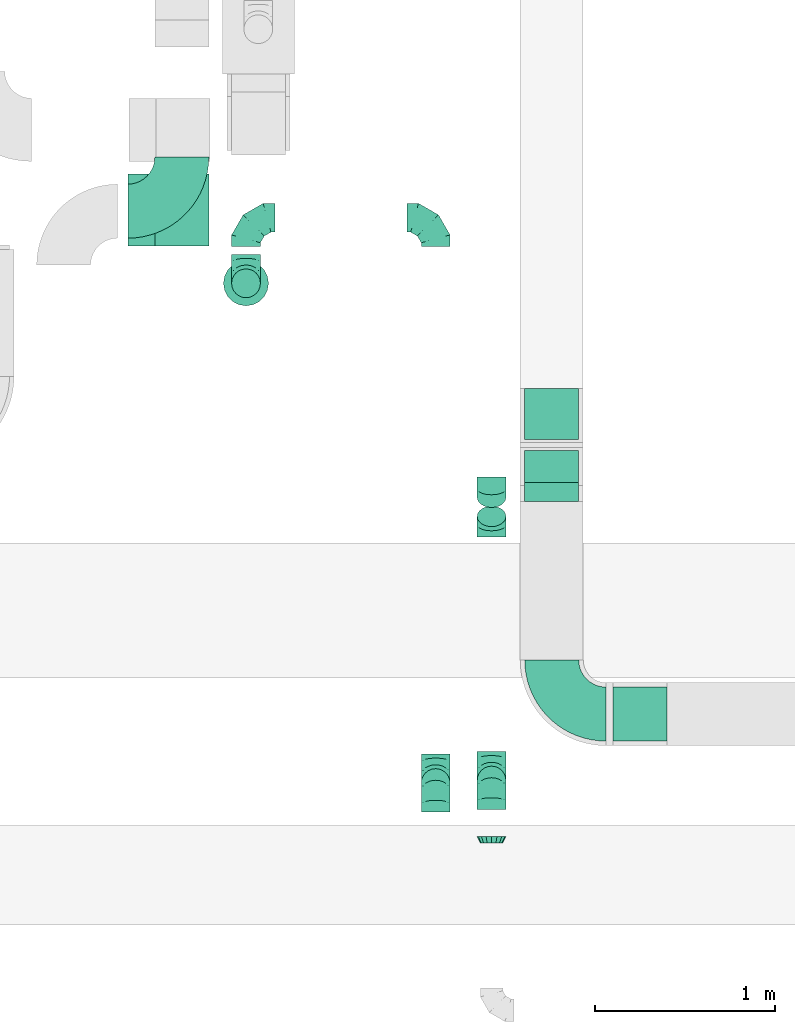
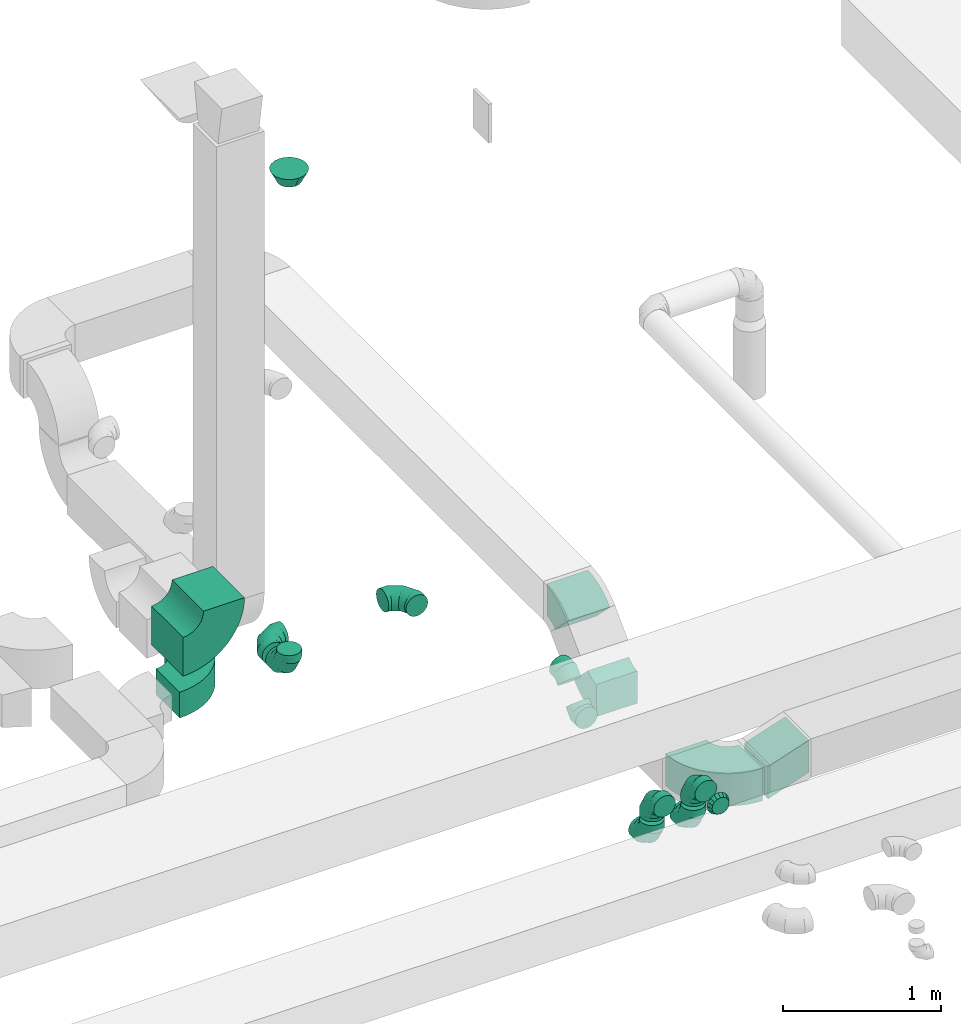
# One storey, part 44 of 97: 17 flow fittings.
"""IFC2X3 building model written with IfcOpenShell, lengths in millimetres."""

from ifc_helpers import new_model, entity, si_unit, converted_unit, derived_unit, direction, frame, frame_2d, origin, place, context, subcontext, project, spatial, polyline, circle_curve, parameter, trimmed, segment, composite_curve, outline, extrude, faceted_brep, source, transform, mapped, material, type_object, type_shapes, element, save


model = new_model("IFC2X3")

# Units and contexts
model_context = context("Model", 3, precision=0.01, world=origin(), true_north=direction((6.12303176911189e-17, 1.0)))
body_context = subcontext(model_context, "Body", "Model", "MODEL_VIEW")
ifc_project = project(units=[si_unit("LENGTHUNIT", "METRE", prefix="MILLI"), si_unit("AREAUNIT", "SQUARE_METRE"), si_unit("VOLUMEUNIT", "CUBIC_METRE"), converted_unit("PLANEANGLEUNIT", "DEGREE", entity("IfcRatioMeasure", 0.0174532925199433), si_unit("PLANEANGLEUNIT", "RADIAN"), dimensions=[0, 0, 0, 0, 0, 0, 0]), si_unit("MASSUNIT", "GRAM", prefix="KILO"), derived_unit("MASSDENSITYUNIT", [(si_unit("MASSUNIT", "GRAM", prefix="KILO"), 1), (si_unit("LENGTHUNIT", "METRE"), -3)]), derived_unit("MOMENTOFINERTIAUNIT", [(si_unit("LENGTHUNIT", "METRE"), 4)]), si_unit("TIMEUNIT", "SECOND"), si_unit("FREQUENCYUNIT", "HERTZ"), si_unit("THERMODYNAMICTEMPERATUREUNIT", "DEGREE_CELSIUS"), derived_unit("THERMALTRANSMITTANCEUNIT", [(si_unit("MASSUNIT", "GRAM", prefix="KILO"), 1), (si_unit("THERMODYNAMICTEMPERATUREUNIT", "KELVIN"), -1), (si_unit("TIMEUNIT", "SECOND"), -3)]), derived_unit("VOLUMETRICFLOWRATEUNIT", [(si_unit("LENGTHUNIT", "METRE"), 3), (si_unit("TIMEUNIT", "SECOND"), -1)]), derived_unit("MASSFLOWRATEUNIT", [(si_unit("MASSUNIT", "GRAM", prefix="KILO"), 1), (si_unit("TIMEUNIT", "SECOND"), -1)]), derived_unit("ROTATIONALFREQUENCYUNIT", [(si_unit("TIMEUNIT", "SECOND"), -1)]), si_unit("ELECTRICCURRENTUNIT", "AMPERE"), si_unit("ELECTRICVOLTAGEUNIT", "VOLT"), si_unit("POWERUNIT", "WATT"), si_unit("FORCEUNIT", "NEWTON", prefix="KILO"), si_unit("ILLUMINANCEUNIT", "LUX"), si_unit("LUMINOUSFLUXUNIT", "LUMEN"), si_unit("LUMINOUSINTENSITYUNIT", "CANDELA"), derived_unit("USERDEFINED", [(si_unit("MASSUNIT", "GRAM", prefix="KILO"), -1), (si_unit("LENGTHUNIT", "METRE"), -2), (si_unit("TIMEUNIT", "SECOND"), 3), (si_unit("LUMINOUSFLUXUNIT", "LUMEN"), 1)]), derived_unit("LINEARVELOCITYUNIT", [(si_unit("LENGTHUNIT", "METRE"), 1), (si_unit("TIMEUNIT", "SECOND"), -1)]), si_unit("PRESSUREUNIT", "PASCAL"), derived_unit("USERDEFINED", [(si_unit("LENGTHUNIT", "METRE"), -2), (si_unit("MASSUNIT", "GRAM", prefix="KILO"), 1), (si_unit("TIMEUNIT", "SECOND"), -2)]), derived_unit("LINEARFORCEUNIT", [(si_unit("MASSUNIT", "GRAM", prefix="KILO"), 1), (si_unit("LENGTHUNIT", "METRE"), 1), (si_unit("TIMEUNIT", "SECOND"), -2), (si_unit("LENGTHUNIT", "METRE"), -1)]), derived_unit("PLANARFORCEUNIT", [(si_unit("MASSUNIT", "GRAM", prefix="KILO"), 1), (si_unit("LENGTHUNIT", "METRE"), 1), (si_unit("TIMEUNIT", "SECOND"), -2), (si_unit("LENGTHUNIT", "METRE"), -2)])], contexts=[model_context])

# Site, building, storey
site_placement = place(None, origin())
site = spatial("IfcSite", under=ifc_project, at=site_placement, CompositionType="ELEMENT")
building_placement = place(site_placement, origin())
building = spatial("IfcBuilding", under=site, at=building_placement, CompositionType="ELEMENT")
storey_placement = place(building_placement, frame((0.0, 0.0, -4900.0)))
storey = spatial("IfcBuildingStorey", under=building, at=storey_placement, CompositionType="ELEMENT", Elevation=-4900.0)

# Flow fittings
ifc_material = material()
duct_fitting_type_1 = type_object("IfcDuctFittingType", PredefinedType="NOTDEFINED", material=ifc_material)
shared_shape_1 = source(origin(), body_context, "Body", "SweptSolid", [
    extrude(outline(polyline([(-197.64, -118.59), (118.59, -118.59), (197.64, 118.59), (-118.59, 118.59), (-197.64, -118.59)])), frame((150.0, -150.0, -50.0), z_axis=(0.0, 1.0, 0.0), x_axis=(0.948683298050436, 0.0, -0.316227766017072)), (0.0, 0.0, 1.0), 300.0),
])
type_shapes(duct_fitting_type_1, [shared_shape_1])
flow_fitting_1_placement = place(storey_placement, frame((33827.72, 9245.01, 4000.0), z_axis=(0.0, 0.0, 1.0), x_axis=(-1.0, 0.0, 0.0)))
element("IfcFlowFitting", 1, at=flow_fitting_1_placement, inside=storey, type_object=duct_fitting_type_1, material=ifc_material, context=body_context, shape_type="MappedRepresentation", body=[
    mapped(shared_shape_1, transform((0.0, 0.0, 0.0), scale=1.0)),
])
duct_fitting_type_2 = type_object("IfcDuctFittingType", PredefinedType="NOTDEFINED", material=ifc_material)
shared_shape_2 = source(origin(), body_context, "Body", "Brep", [
    faceted_brep([(-160.0, 0.0, -80.0), (-160.0, -20.71, -77.27), (-160.0, -40.0, -69.28), (-160.0, -56.57, -56.57), (-160.0, -69.28, -40.0), (-160.0, -77.27, -20.71), (-160.0, -80.0, 0.0), (-160.0, -77.27, 20.71), (-160.0, -69.28, 40.0), (-160.0, -56.57, 56.57), (-160.0, -40.0, 69.28), (-160.0, -20.71, 77.27), (-160.0, 0.0, 80.0), (-160.0, 20.71, 77.27), (-160.0, 40.0, 69.28), (-160.0, 56.57, 56.57), (-160.0, 69.28, 40.0), (-160.0, 77.27, 20.71), (-160.0, 80.0, 0.0), (-160.0, 77.27, -20.71), (-160.0, 69.28, -40.0), (-160.0, 56.57, -56.57), (-160.0, 40.0, -69.28), (-160.0, 20.71, -77.27), (-122.68, 20.71, 77.27), (-127.85, 40.0, 69.28), (-117.13, 0.0, 80.0), (-132.29, 56.57, 56.57), (-137.83, 77.27, 20.71), (-138.56, 80.0, 0.0), (-135.69, 69.28, 40.0), (-135.69, 69.28, -40.0), (-132.29, 56.57, -56.57), (-137.83, 77.27, -20.71), (-122.68, 20.71, -77.27), (-117.13, 0.0, -80.0), (-127.85, 40.0, -69.28), (-111.58, -20.71, -77.27), (-106.41, -40.0, -69.28), (-101.97, -56.57, -56.57), (-98.56, -69.28, -40.0), (-96.42, -77.27, -20.71), (-95.69, -80.0, 0.0), (-96.42, -77.27, 20.71), (-98.56, -69.28, 40.0), (-101.97, -56.57, 56.57), (-106.41, -40.0, 69.28), (-111.58, -20.71, 77.27), (-58.03, 58.03, 77.27), (-72.15, 72.15, 69.28), (-42.87, 42.87, 80.0), (-84.28, 84.28, 56.57), (-93.59, 93.59, 40.0), (-99.44, 99.44, 20.71), (-101.44, 101.44, 0.0), (-99.44, 99.44, -20.71), (-93.59, 93.59, -40.0), (-84.28, 84.28, -56.57), (-58.03, 58.03, -77.27), (-42.87, 42.87, -80.0), (-72.15, 72.15, -69.28), (-27.71, 27.71, -77.27), (-13.59, 13.59, -69.28), (-1.46, 1.46, -56.57), (7.85, -7.85, -40.0), (13.7, -13.7, -20.71), (15.69, -15.69, 0.0), (13.7, -13.7, 20.71), (7.85, -7.85, 40.0), (-1.46, 1.46, 56.57), (-13.59, 13.59, 69.28), (-27.71, 27.71, 77.27), (-20.71, 122.68, 77.27), (-40.0, 127.85, 69.28), (0.0, 117.13, 80.0), (-56.57, 132.29, 56.57), (-69.28, 135.69, 40.0), (-77.27, 137.83, 20.71), (-80.0, 138.56, 0.0), (-77.27, 137.83, -20.71), (-69.28, 135.69, -40.0), (-56.57, 132.29, -56.57), (-20.71, 122.68, -77.27), (0.0, 117.13, -80.0), (-40.0, 127.85, -69.28), (20.71, 111.58, -77.27), (40.0, 106.41, -69.28), (56.57, 101.97, -56.57), (69.28, 98.56, -40.0), (77.27, 96.42, -20.71), (80.0, 95.69, 0.0), (77.27, 96.42, 20.71), (69.28, 98.56, 40.0), (56.57, 101.97, 56.57), (40.0, 106.41, 69.28), (20.71, 111.58, 77.27), (-20.71, 160.0, -77.27), (-40.0, 160.0, -69.28), (-56.57, 160.0, -56.57), (-69.28, 160.0, -40.0), (-77.27, 160.0, -20.71), (-80.0, 160.0, 0.0), (-77.27, 160.0, 20.71), (-69.28, 160.0, 40.0), (-56.57, 160.0, 56.57), (-40.0, 160.0, 69.28), (-20.71, 160.0, 77.27), (0.0, 160.0, 80.0), (20.71, 160.0, 77.27), (40.0, 160.0, 69.28), (56.57, 160.0, 56.57), (69.28, 160.0, 40.0), (77.27, 160.0, 20.71), (80.0, 160.0, 0.0), (77.27, 160.0, -20.71), (69.28, 160.0, -40.0), (56.57, 160.0, -56.57), (40.0, 160.0, -69.28), (20.71, 160.0, -77.27), (0.0, 160.0, -80.0)], [[[0, 1, 2, 3, 4, 5, 6, 7, 8, 9, 10, 11, 12, 13, 14, 15, 16, 17, 18, 19, 20, 21, 22, 23]], [[24, 25, 14, 13]], [[26, 24, 13, 12]], [[14, 25, 27, 15]], [[28, 29, 18, 17]], [[30, 28, 17, 16]], [[15, 27, 30, 16]], [[20, 31, 32, 21]], [[33, 31, 20, 19]], [[18, 29, 33, 19]], [[34, 35, 0, 23]], [[36, 34, 23, 22]], [[32, 36, 22, 21]], [[1, 0, 35, 37]], [[2, 1, 37, 38]], [[3, 2, 38, 39]], [[5, 4, 40, 41]], [[6, 5, 41, 42]], [[39, 40, 4, 3]], [[6, 42, 43, 7]], [[7, 43, 44, 8]], [[8, 44, 45, 9]], [[9, 45, 46, 10]], [[10, 46, 47, 11]], [[26, 12, 11, 47]], [[48, 49, 25, 24]], [[50, 48, 24, 26]], [[27, 25, 49, 51]], [[52, 53, 28, 30]], [[51, 52, 30, 27]], [[29, 28, 53, 54]], [[55, 56, 31, 33]], [[54, 55, 33, 29]], [[32, 31, 56, 57]], [[58, 59, 35, 34]], [[60, 58, 34, 36]], [[57, 60, 36, 32]], [[37, 35, 59, 61]], [[38, 37, 61, 62]], [[39, 38, 62, 63]], [[41, 40, 64, 65]], [[42, 41, 65, 66]], [[63, 64, 40, 39]], [[43, 42, 66, 67]], [[44, 43, 67, 68]], [[68, 69, 45, 44]], [[46, 45, 69, 70]], [[47, 46, 70, 71]], [[26, 47, 71, 50]], [[72, 73, 49, 48]], [[74, 72, 48, 50]], [[51, 49, 73, 75]], [[76, 77, 53, 52]], [[75, 76, 52, 51]], [[54, 53, 77, 78]], [[79, 80, 56, 55]], [[78, 79, 55, 54]], [[57, 56, 80, 81]], [[82, 83, 59, 58]], [[84, 82, 58, 60]], [[81, 84, 60, 57]], [[61, 59, 83, 85]], [[62, 61, 85, 86]], [[63, 62, 86, 87]], [[65, 64, 88, 89]], [[66, 65, 89, 90]], [[87, 88, 64, 63]], [[67, 66, 90, 91]], [[68, 67, 91, 92]], [[92, 93, 69, 68]], [[70, 69, 93, 94]], [[71, 70, 94, 95]], [[50, 71, 95, 74]], [[96, 97, 98, 99, 100, 101, 102, 103, 104, 105, 106, 107, 108, 109, 110, 111, 112, 113, 114, 115, 116, 117, 118, 119]], [[72, 74, 107, 106]], [[73, 72, 106, 105]], [[75, 73, 105, 104]], [[77, 76, 103, 102]], [[78, 77, 102, 101]], [[75, 104, 103, 76]], [[78, 101, 100, 79]], [[79, 100, 99, 80]], [[80, 99, 98, 81]], [[84, 97, 96, 82]], [[82, 96, 119, 83]], [[84, 81, 98, 97]], [[118, 117, 86, 85]], [[119, 118, 85, 83]], [[116, 87, 86, 117]], [[88, 115, 114, 89]], [[89, 114, 113, 90]], [[115, 88, 87, 116]], [[112, 111, 92, 91]], [[113, 112, 91, 90]], [[111, 110, 93, 92]], [[95, 94, 109, 108]], [[74, 95, 108, 107]], [[110, 109, 94, 93]]]),
])
type_shapes(duct_fitting_type_2, [shared_shape_2])
for number, where, z_axis, x_axis in (
    (2, (31490.77, 12001.42, 3950.0), (0.0, 0.0, 1.0), (-1.0, 0.0, 0.0)),
    (3, (31490.77, 11637.41, 3950.0), (-1.0, 0.0, 0.0), (0.0, -1.0, 0.0)),
    (4, (32854.47, 8875.84, 3950.0), (-1.0, 0.0, 0.0), (0.0, -1.0, 0.0)),
    (5, (32854.47, 8875.84, 4300.0), (1.0, 0.0, 0.0), (0.0, 0.0, 1.0)),
    (6, (32544.11, 8861.92, 4300.0), (-1.0, 0.0, 0.0), (0.0, 1.0, 0.0)),
    (7, (32544.11, 8861.92, 3950.0), (1.0, 0.0, 0.0), (0.0, 0.0, -1.0)),
    (8, (32544.11, 12001.42, 3950.0), (0.0, 0.0, 1.0), (0.0, 1.0, 0.0)),
):
    element("IfcFlowFitting", number, at=place(storey_placement, frame(where, z_axis=z_axis, x_axis=x_axis)), inside=storey, type_object=duct_fitting_type_2, material=ifc_material, context=body_context, shape_type="MappedRepresentation", body=[
        mapped(shared_shape_2, transform((0.0, 0.0, 0.0), scale=1.0)),
    ])
duct_fitting_type_3 = type_object("IfcDuctFittingType", PredefinedType="NOTDEFINED", material=ifc_material)
shared_shape_3 = source(origin(), body_context, "Body", "Brep", [
    faceted_brep([(35.0, -57.74, 23.92), (35.0, -60.12, 11.96), (35.0, -62.5, 0.0), (35.0, -60.12, -11.96), (35.0, -57.74, -23.92), (35.0, -50.97, -34.06), (35.0, -44.19, -44.19), (35.0, -34.06, -50.97), (35.0, -23.92, -57.74), (35.0, -11.96, -60.12), (35.0, 0.0, -62.5), (35.0, 11.96, -60.12), (35.0, 23.92, -57.74), (35.0, 34.06, -50.97), (35.0, 44.19, -44.19), (35.0, 50.97, -34.06), (35.0, 57.74, -23.92), (35.0, 60.12, -11.96), (35.0, 62.5, 0.0), (35.0, 60.12, 11.96), (35.0, 57.74, 23.92), (35.0, 50.97, 34.06), (35.0, 44.19, 44.19), (35.0, 34.06, 50.97), (35.0, 23.92, 57.74), (35.0, 11.96, 60.12), (35.0, 0.0, 62.5), (35.0, -11.96, 60.12), (35.0, -23.92, 57.74), (35.0, -34.06, 50.97), (35.0, -44.19, 44.19), (35.0, -50.97, 34.06), (0.0, -80.0, 0.0), (0.0, -77.45, 12.81), (0.0, -73.91, 30.61), (0.0, -65.24, 43.59), (0.0, -56.57, 56.57), (0.0, -43.59, 65.24), (0.0, -30.61, 73.91), (0.0, -12.81, 77.45), (0.0, 0.0, 80.0), (0.0, 12.81, 77.45), (0.0, 30.61, 73.91), (0.0, 43.59, 65.24), (0.0, 56.57, 56.57), (0.0, 65.24, 43.59), (0.0, 73.91, 30.61), (0.0, 77.45, 12.81), (0.0, 80.0, 0.0), (0.0, 77.45, -12.81), (0.0, 73.91, -30.61), (0.0, 65.24, -43.59), (0.0, 56.57, -56.57), (0.0, 43.59, -65.24), (0.0, 30.61, -73.91), (0.0, 12.81, -77.45), (0.0, 0.0, -80.0), (0.0, -12.81, -77.45), (0.0, -30.61, -73.91), (0.0, -43.59, -65.24), (0.0, -56.57, -56.57), (0.0, -65.24, -43.59), (0.0, -73.91, -30.61), (0.0, -77.45, -12.81)], [[[0, 1, 2, 3, 4, 5, 6, 7, 8, 9, 10, 11, 12, 13, 14, 15, 16, 17, 18, 19, 20, 21, 22, 23, 24, 25, 26, 27, 28, 29, 30, 31]], [[32, 33, 34, 35, 36, 37, 38, 39, 40, 41, 42, 43, 44, 45, 46, 47, 48, 49, 50, 51, 52, 53, 54, 55, 56, 57, 58, 59, 60, 61, 62, 63]], [[24, 23, 22, 44, 43, 42]], [[20, 46, 45, 44, 22, 21]], [[42, 41, 40, 26, 25, 24]], [[47, 46, 20, 19, 18, 48]], [[0, 31, 30, 36, 35, 34]], [[28, 38, 37, 36, 30, 29]], [[34, 33, 32, 2, 1, 0]], [[39, 38, 28, 27, 26, 40]], [[8, 7, 6, 60, 59, 58]], [[4, 62, 61, 60, 6, 5]], [[58, 57, 56, 10, 9, 8]], [[63, 62, 4, 3, 2, 32]], [[16, 15, 14, 52, 51, 50]], [[12, 54, 53, 52, 14, 13]], [[50, 49, 48, 18, 17, 16]], [[55, 54, 12, 11, 10, 56]]]),
])
type_shapes(duct_fitting_type_3, [shared_shape_3])
flow_fitting_2_placement = place(storey_placement, frame((32854.47, 8564.77, 4300.0), z_axis=(0.0, 0.0, 1.0), x_axis=(0.0, -1.0, 0.0)))
element("IfcFlowFitting", 9, at=flow_fitting_2_placement, inside=storey, type_object=duct_fitting_type_3, material=ifc_material, context=body_context, shape_type="MappedRepresentation", body=[
    mapped(shared_shape_3, transform((0.0, 0.0, 0.0), scale=1.0)),
])
duct_fitting_type_4 = type_object("IfcDuctFittingType", PredefinedType="NOTDEFINED", material=ifc_material)
shared_shape_4 = source(origin(), body_context, "Body", "Brep", [
    faceted_brep([(-66.27, 0.0, -80.0), (-66.27, -20.71, -77.27), (-66.27, -40.0, -69.28), (-66.27, -56.57, -56.57), (-66.27, -69.28, -40.0), (-66.27, -77.27, -20.71), (-66.27, -80.0, 0.0), (-66.27, -77.27, 20.71), (-66.27, -69.28, 40.0), (-66.27, -56.57, 56.57), (-66.27, -40.0, 69.28), (-66.27, -20.71, 77.27), (-66.27, 0.0, 80.0), (-66.27, 20.71, 77.27), (-66.27, 40.0, 69.28), (-66.27, 56.57, 56.57), (-66.27, 69.28, 40.0), (-66.27, 77.27, 20.71), (-66.27, 80.0, 0.0), (-66.27, 77.27, -20.71), (-66.27, 69.28, -40.0), (-66.27, 56.57, -56.57), (-66.27, 40.0, -69.28), (-66.27, 20.71, -77.27), (-8.58, 20.71, 77.27), (-16.57, 40.0, 69.28), (0.0, 0.0, 80.0), (-23.43, 56.57, 56.57), (-28.7, 69.28, 40.0), (-32.01, 77.27, 20.71), (-33.14, 80.0, 0.0), (-32.01, 77.27, -20.71), (-28.7, 69.28, -40.0), (-23.43, 56.57, -56.57), (-8.58, 20.71, -77.27), (0.0, 0.0, -80.0), (-16.57, 40.0, -69.28), (8.58, -20.71, -77.27), (16.57, -40.0, -69.28), (23.43, -56.57, -56.57), (28.7, -69.28, -40.0), (32.01, -77.27, -20.71), (33.14, -80.0, 0.0), (32.01, -77.27, 20.71), (28.7, -69.28, 40.0), (23.43, -56.57, 56.57), (16.57, -40.0, 69.28), (8.58, -20.71, 77.27), (46.86, 46.86, 80.0), (32.22, 61.5, 77.27), (18.58, 75.15, 69.28), (6.86, 86.86, 56.57), (-2.13, 95.85, 40.0), (-7.78, 101.5, 20.71), (-9.71, 103.43, 0.0), (-7.78, 101.5, -20.71), (-2.13, 95.85, -40.0), (6.86, 86.86, -56.57), (18.58, 75.15, -69.28), (32.22, 61.5, -77.27), (46.86, 46.86, -80.0), (61.5, 32.22, -77.27), (75.15, 18.58, -69.28), (86.86, 6.86, -56.57), (95.85, -2.13, -40.0), (101.5, -7.78, -20.71), (103.43, -9.71, 0.0), (101.5, -7.78, 20.71), (95.85, -2.13, 40.0), (86.86, 6.86, 56.57), (75.15, 18.58, 69.28), (61.5, 32.22, 77.27)], [[[0, 1, 2, 3, 4, 5, 6, 7, 8, 9, 10, 11, 12, 13, 14, 15, 16, 17, 18, 19, 20, 21, 22, 23]], [[24, 25, 14, 13]], [[26, 24, 13, 12]], [[14, 25, 27, 15]], [[28, 29, 17, 16]], [[28, 16, 15, 27]], [[30, 18, 17, 29]], [[31, 32, 20, 19]], [[30, 31, 19, 18]], [[32, 33, 21, 20]], [[34, 35, 0, 23]], [[36, 34, 23, 22]], [[33, 36, 22, 21]], [[1, 0, 35, 37]], [[2, 1, 37, 38]], [[38, 39, 3, 2]], [[5, 4, 40, 41]], [[6, 5, 41, 42]], [[39, 40, 4, 3]], [[6, 42, 43, 7]], [[7, 43, 44, 8]], [[8, 44, 45, 9]], [[9, 45, 46, 10]], [[10, 46, 47, 11]], [[26, 12, 11, 47]], [[24, 26, 48, 49]], [[25, 24, 49, 50]], [[27, 25, 50, 51]], [[29, 28, 52, 53]], [[30, 29, 53, 54]], [[51, 52, 28, 27]], [[30, 54, 55, 31]], [[31, 55, 56, 32]], [[57, 33, 32, 56]], [[36, 58, 59, 34]], [[34, 59, 60, 35]], [[58, 36, 33, 57]], [[35, 60, 61, 37]], [[37, 61, 62, 38]], [[63, 39, 38, 62]], [[40, 64, 65, 41]], [[41, 65, 66, 42]], [[64, 40, 39, 63]], [[43, 42, 66, 67]], [[44, 43, 67, 68]], [[68, 69, 45, 44]], [[47, 46, 70, 71]], [[26, 47, 71, 48]], [[69, 70, 46, 45]], [[59, 58, 57, 56, 55, 54, 53, 52, 51, 50, 49, 48, 71, 70, 69, 68, 67, 66, 65, 64, 63, 62, 61, 60]]]),
])
type_shapes(duct_fitting_type_4, [shared_shape_4])
for number, where, z_axis, x_axis in (
    (10, (32854.47, 10495.84, 4150.0), (1.0, 0.0, 0.0), (0.0, -1.0, 0.0)),
    (11, (32854.47, 10295.84, 3950.0), (-1.0, 0.0, 0.0), (0.0, -0.707106781186524, -0.707106781186571)),
):
    element("IfcFlowFitting", number, at=place(storey_placement, frame(where, z_axis=z_axis, x_axis=x_axis)), inside=storey, type_object=duct_fitting_type_4, material=ifc_material, context=body_context, shape_type="MappedRepresentation", body=[
        mapped(shared_shape_4, transform((0.0, 0.0, 0.0), scale=1.0)),
    ])
duct_fitting_type_5 = type_object("IfcDuctFittingType", PredefinedType="NOTDEFINED", material=ifc_material)
shared_shape_5 = source(origin(), body_context, "Body", "Brep", [
    faceted_brep([(90.0, -73.47, -101.13), (90.0, -38.63, -118.88), (90.0, 0.0, -125.0), (90.0, 38.63, -118.88), (90.0, 73.47, -101.13), (90.0, 101.13, -73.47), (90.0, 118.88, -38.63), (90.0, 125.0, 0.0), (90.0, 118.88, 38.63), (90.0, 101.13, 73.47), (90.0, 73.47, 101.13), (90.0, 38.63, 118.88), (90.0, 0.0, 125.0), (90.0, -38.63, 118.88), (90.0, -73.47, 101.13), (90.0, -101.13, 73.47), (90.0, -118.88, 38.63), (90.0, -125.0, 0.0), (90.0, -118.88, -38.63), (90.0, -101.13, -73.47), (0.0, -30.61, -73.91), (0.0, -43.59, -65.24), (0.0, -56.57, -56.57), (0.0, -65.24, -43.59), (0.0, -73.91, -30.61), (0.0, -76.96, -15.31), (0.0, -80.0, 0.0), (0.0, -76.96, 15.31), (0.0, -73.91, 30.61), (0.0, -65.24, 43.59), (0.0, -56.57, 56.57), (0.0, -43.59, 65.24), (0.0, -30.61, 73.91), (0.0, -15.31, 76.96), (0.0, 0.0, 80.0), (0.0, 15.31, 76.96), (0.0, 30.61, 73.91), (0.0, 43.59, 65.24), (0.0, 56.57, 56.57), (0.0, 65.24, 43.59), (0.0, 73.91, 30.61), (0.0, 76.96, 15.31), (0.0, 80.0, 0.0), (0.0, 76.96, -15.31), (0.0, 73.91, -30.61), (0.0, 65.24, -43.59), (0.0, 56.57, -56.57), (0.0, 43.59, -65.24), (0.0, 30.61, -73.91), (0.0, 15.31, -76.96), (0.0, 0.0, -80.0), (0.0, -15.31, -76.96)], [[[0, 1, 2, 3, 4, 5, 6, 7, 8, 9, 10, 11, 12, 13, 14, 15, 16, 17, 18, 19]], [[20, 21, 22, 23, 24, 25, 26, 27, 28, 29, 30, 31, 32, 33, 34, 35, 36, 37, 38, 39, 40, 41, 42, 43, 44, 45, 46, 47, 48, 49, 50, 51]], [[7, 41, 8]], [[41, 40, 8]], [[40, 9, 8]], [[11, 36, 35]], [[41, 7, 42]], [[9, 40, 39, 38]], [[10, 38, 37, 36]], [[12, 35, 34]], [[11, 10, 36]], [[12, 11, 35]], [[38, 10, 9]], [[12, 33, 13]], [[33, 32, 13]], [[32, 14, 13]], [[16, 28, 27]], [[33, 12, 34]], [[14, 32, 31, 30]], [[15, 30, 29, 28]], [[17, 27, 26]], [[16, 15, 28]], [[17, 16, 27]], [[30, 15, 14]], [[17, 25, 18]], [[25, 24, 18]], [[24, 19, 18]], [[1, 20, 51]], [[25, 17, 26]], [[19, 24, 23, 22]], [[0, 22, 21, 20]], [[2, 51, 50]], [[1, 0, 20]], [[2, 1, 51]], [[22, 0, 19]], [[2, 49, 3]], [[49, 48, 3]], [[48, 4, 3]], [[6, 44, 43]], [[49, 2, 50]], [[4, 48, 47, 46]], [[5, 46, 45, 44]], [[7, 43, 42]], [[6, 5, 44]], [[7, 6, 43]], [[46, 5, 4]]]),
])
type_shapes(duct_fitting_type_5, [shared_shape_5])
flow_fitting_3_placement = place(storey_placement, frame((31490.77, 11637.41, 7735.0), z_axis=(0.0, 1.0, 0.0), x_axis=(0.0, 0.0, 1.0)))
element("IfcFlowFitting", 12, at=flow_fitting_3_placement, inside=storey, type_object=duct_fitting_type_5, material=ifc_material, context=body_context, shape_type="MappedRepresentation", body=[
    mapped(shared_shape_5, transform((0.0, 0.0, 0.0), scale=1.0)),
])
duct_fitting_type_6 = type_object("IfcDuctFittingType", PredefinedType="NOTDEFINED", material=ifc_material)
shared_shape_6 = source(origin(), body_context, "Body", "SweptSolid", [
    extrude(outline(composite_curve([segment(polyline([(-300.0, -150.0), (0.0, -150.0)]), True, "CONTINUOUS"), segment(trimmed(circle_curve(frame_2d((150.0, -150.0), x_axis=(0.0, 1.0)), 150.0), [parameter(0.0)], [parameter(90.0)], True, "PARAMETER"), False, "CONTINUOUS"), segment(polyline([(150.0, 0.0), (150.0, 300.0)]), True, "CONTINUOUS"), segment(trimmed(circle_curve(frame_2d((150.0, -150.0), x_axis=(0.0, 1.0)), 450.0), [parameter(0.0)], [parameter(90.0000000000001)], True, "PARAMETER"), True, "CONTINUOUS")], self_intersect=False)), frame((-150.0, 150.0, -125.0), z_axis=(0.0, 0.0, 1.0), x_axis=(-1.0, 0.0, 0.0)), (0.0, 0.0, 1.0), 250.0),
])
type_shapes(duct_fitting_type_6, [shared_shape_6])
flow_fitting_4_placement = place(storey_placement, frame((33188.7, 9245.01, 3900.0), z_axis=(0.0, 0.0, 1.0), x_axis=(0.0, -1.0, 0.0)))
element("IfcFlowFitting", 13, at=flow_fitting_4_placement, inside=storey, type_object=duct_fitting_type_6, material=ifc_material, context=body_context, shape_type="MappedRepresentation", body=[
    mapped(shared_shape_6, transform((0.0, 0.0, 0.0), scale=1.0)),
])
duct_fitting_type_7 = type_object("IfcDuctFittingType", PredefinedType="NOTDEFINED", material=ifc_material)
shared_shape_7 = source(origin(), body_context, "Body", "SweptSolid", [
    extrude(outline(composite_curve([segment(polyline([(-300.0, -150.0), (0.0, -150.0)]), True, "CONTINUOUS"), segment(trimmed(circle_curve(frame_2d((150.0, -150.0), x_axis=(0.0, 1.0)), 150.0), [parameter(0.0)], [parameter(90.0)], True, "PARAMETER"), False, "CONTINUOUS"), segment(polyline([(150.0, 0.0), (150.0, 300.0)]), True, "CONTINUOUS"), segment(trimmed(circle_curve(frame_2d((150.0, -150.0), x_axis=(0.0, 1.0)), 450.0), [parameter(0.0)], [parameter(90.0000000000001)], True, "PARAMETER"), True, "CONTINUOUS")], self_intersect=False)), frame((-150.0, 150.0, -100.0), z_axis=(0.0, 0.0, 1.0), x_axis=(-1.0, 0.0, 0.0)), (0.0, 0.0, 1.0), 200.0),
])
type_shapes(duct_fitting_type_7, [shared_shape_7])
flow_fitting_5_placement = place(storey_placement, frame((31134.29, 12038.04, 3750.0)))
element("IfcFlowFitting", 14, at=flow_fitting_5_placement, inside=storey, type_object=duct_fitting_type_7, material=ifc_material, context=body_context, shape_type="MappedRepresentation", body=[
    mapped(shared_shape_7, transform((0.0, 0.0, 0.0), scale=1.0)),
])
duct_fitting_type_8 = type_object("IfcDuctFittingType", PredefinedType="NOTDEFINED", material=ifc_material)
shared_shape_8 = source(origin(), body_context, "Body", "SweptSolid", [
    extrude(outline(composite_curve([segment(polyline([(-165.27, -97.23), (84.73, -97.23)]), True, "CONTINUOUS"), segment(trimmed(circle_curve(frame_2d((234.73, -97.23), x_axis=(-0.707106781186546, 0.707106781186546)), 150.0), [parameter(0.0)], [parameter(45.0)], True, "PARAMETER"), False, "CONTINUOUS"), segment(polyline([(128.66, 8.84), (-48.12, 185.62)]), True, "CONTINUOUS"), segment(trimmed(circle_curve(frame_2d((234.73, -97.23), x_axis=(-0.707106781186546, 0.707106781186546)), 400.0), [parameter(0.0)], [parameter(45.0)], True, "PARAMETER"), True, "CONTINUOUS")], self_intersect=False)), frame((-16.68, 40.27, -150.0), z_axis=(0.0, 0.0, 1.0), x_axis=(-0.707106781186547, 0.707106781186548, 0.0)), (0.0, 0.0, 1.0), 300.0),
])
type_shapes(duct_fitting_type_8, [shared_shape_8])
for number, where, z_axis, x_axis in (
    (15, (33188.7, 10938.66, 4300.0), (1.0, 0.0, 0.0), (0.0, -1.0, 0.0)),
    (16, (33188.7, 10538.66, 3900.0), (-1.0, 0.0, 0.0), (0.0, -0.70710678118652, -0.707106781186575)),
):
    element("IfcFlowFitting", number, at=place(storey_placement, frame(where, z_axis=z_axis, x_axis=x_axis)), inside=storey, type_object=duct_fitting_type_8, material=ifc_material, context=body_context, shape_type="MappedRepresentation", body=[
        mapped(shared_shape_8, transform((0.0, 0.0, 0.0), scale=1.0)),
    ])
duct_fitting_type_9 = type_object("IfcDuctFittingType", PredefinedType="NOTDEFINED", material=ifc_material)
shared_shape_9 = source(origin(), body_context, "Body", "SweptSolid", [
    extrude(outline(composite_curve([segment(polyline([(-300.0, -150.0), (0.0, -150.0)]), True, "CONTINUOUS"), segment(trimmed(circle_curve(frame_2d((150.0, -150.0), x_axis=(0.0, 1.0)), 150.0), [parameter(0.0)], [parameter(90.0)], True, "PARAMETER"), False, "CONTINUOUS"), segment(polyline([(150.0, 0.0), (150.0, 300.0)]), True, "CONTINUOUS"), segment(trimmed(circle_curve(frame_2d((150.0, -150.0), x_axis=(0.0, 1.0)), 450.0), [parameter(0.0)], [parameter(90.0000000000001)], True, "PARAMETER"), True, "CONTINUOUS")], self_intersect=False)), frame((-150.0, 150.0, -200.0), z_axis=(0.0, 0.0, 1.0), x_axis=(-1.0, 0.0, 0.0)), (0.0, 0.0, 1.0), 400.0),
])
type_shapes(duct_fitting_type_9, [shared_shape_9])
flow_fitting_6_placement = place(storey_placement, frame((31134.29, 12045.06, 4150.0), z_axis=(0.0, -1.0, 0.0), x_axis=(1.0, 0.0, 0.0)))
element("IfcFlowFitting", 17, at=flow_fitting_6_placement, inside=storey, type_object=duct_fitting_type_9, material=ifc_material, context=body_context, shape_type="MappedRepresentation", body=[
    mapped(shared_shape_9, transform((0.0, 0.0, 0.0), scale=1.0)),
])

save(model, "model.ifc")
